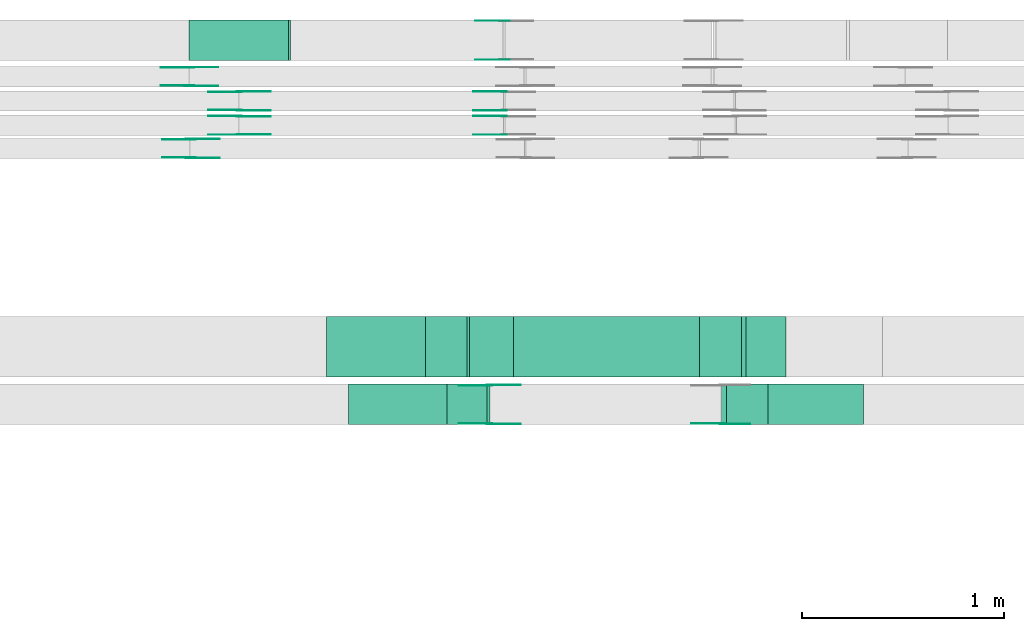
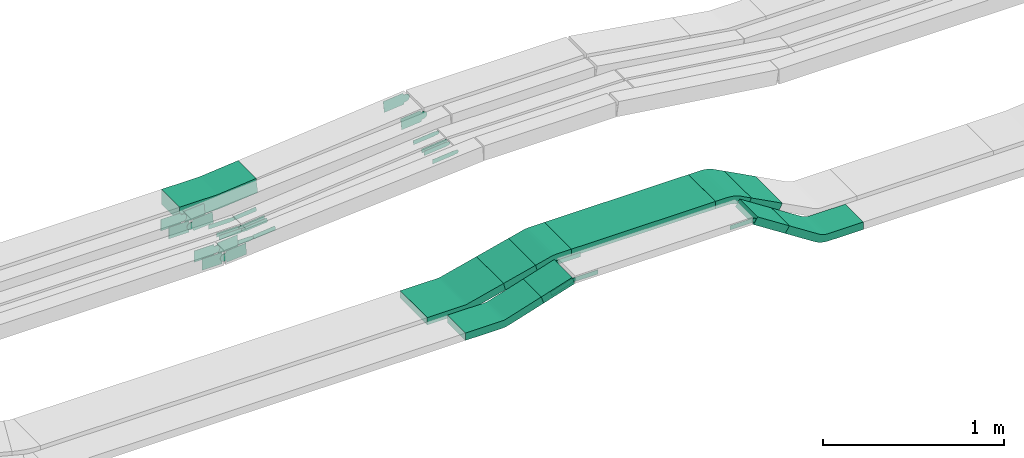
# One storey, part 17 of 28: 34 flow fittings, 5 flow segments.
"""IFC2X3 building model written with IfcOpenShell, lengths in millimetres."""

from ifc_helpers import new_model, entity, si_unit, converted_unit, derived_unit, direction, frame, frame_2d, origin, origin_2d_with_axis, place, context, subcontext, project, spatial, polyline, circle_curve, parameter, trimmed, segment, composite_curve, rectangle, outline, extrude, source, transform, mapped, material, type_object, type_shapes, element, save


model = new_model("IFC2X3")

# Units and contexts
model_context = context("Model", 3, precision=0.01, world=origin(), true_north=direction((6.12303176911189e-17, 1.0)))
body_context = subcontext(model_context, "Body", "Model", "MODEL_VIEW")
ifc_project = project(units=[si_unit("LENGTHUNIT", "METRE", prefix="MILLI"), si_unit("AREAUNIT", "SQUARE_METRE"), si_unit("VOLUMEUNIT", "CUBIC_METRE"), converted_unit("PLANEANGLEUNIT", "DEGREE", entity("IfcRatioMeasure", 0.0174532925199433), si_unit("PLANEANGLEUNIT", "RADIAN"), dimensions=[0, 0, 0, 0, 0, 0, 0]), si_unit("MASSUNIT", "GRAM", prefix="KILO"), derived_unit("MASSDENSITYUNIT", [(si_unit("MASSUNIT", "GRAM", prefix="KILO"), 1), (si_unit("LENGTHUNIT", "METRE"), -3)]), derived_unit("MOMENTOFINERTIAUNIT", [(si_unit("LENGTHUNIT", "METRE"), 4)]), si_unit("TIMEUNIT", "SECOND"), si_unit("FREQUENCYUNIT", "HERTZ"), si_unit("THERMODYNAMICTEMPERATUREUNIT", "DEGREE_CELSIUS"), derived_unit("THERMALTRANSMITTANCEUNIT", [(si_unit("MASSUNIT", "GRAM", prefix="KILO"), 1), (si_unit("THERMODYNAMICTEMPERATUREUNIT", "KELVIN"), -1), (si_unit("TIMEUNIT", "SECOND"), -3)]), derived_unit("VOLUMETRICFLOWRATEUNIT", [(si_unit("LENGTHUNIT", "METRE"), 3), (si_unit("TIMEUNIT", "SECOND"), -1)]), derived_unit("MASSFLOWRATEUNIT", [(si_unit("MASSUNIT", "GRAM", prefix="KILO"), 1), (si_unit("TIMEUNIT", "SECOND"), -1)]), derived_unit("ROTATIONALFREQUENCYUNIT", [(si_unit("TIMEUNIT", "SECOND"), -1)]), si_unit("ELECTRICCURRENTUNIT", "AMPERE"), si_unit("ELECTRICVOLTAGEUNIT", "VOLT"), si_unit("POWERUNIT", "WATT"), si_unit("FORCEUNIT", "NEWTON", prefix="KILO"), si_unit("ILLUMINANCEUNIT", "LUX"), si_unit("LUMINOUSFLUXUNIT", "LUMEN"), si_unit("LUMINOUSINTENSITYUNIT", "CANDELA"), derived_unit("USERDEFINED", [(si_unit("MASSUNIT", "GRAM", prefix="KILO"), -1), (si_unit("LENGTHUNIT", "METRE"), -2), (si_unit("TIMEUNIT", "SECOND"), 3), (si_unit("LUMINOUSFLUXUNIT", "LUMEN"), 1)]), derived_unit("LINEARVELOCITYUNIT", [(si_unit("LENGTHUNIT", "METRE"), 1), (si_unit("TIMEUNIT", "SECOND"), -1)]), si_unit("PRESSUREUNIT", "PASCAL"), derived_unit("USERDEFINED", [(si_unit("LENGTHUNIT", "METRE"), -2), (si_unit("MASSUNIT", "GRAM", prefix="KILO"), 1), (si_unit("TIMEUNIT", "SECOND"), -2)]), derived_unit("LINEARFORCEUNIT", [(si_unit("MASSUNIT", "GRAM", prefix="KILO"), 1), (si_unit("LENGTHUNIT", "METRE"), 1), (si_unit("TIMEUNIT", "SECOND"), -2), (si_unit("LENGTHUNIT", "METRE"), -1)]), derived_unit("PLANARFORCEUNIT", [(si_unit("MASSUNIT", "GRAM", prefix="KILO"), 1), (si_unit("LENGTHUNIT", "METRE"), 1), (si_unit("TIMEUNIT", "SECOND"), -2), (si_unit("LENGTHUNIT", "METRE"), -2)])], contexts=[model_context])

# Site, building, storey
site_placement = place(None, origin())
site = spatial("IfcSite", under=ifc_project, at=site_placement, CompositionType="ELEMENT")
building_placement = place(site_placement, origin())
building = spatial("IfcBuilding", under=site, at=building_placement, CompositionType="ELEMENT")
storey_placement = place(building_placement, frame((0.0, 0.0, 15900.0)))
storey = spatial("IfcBuildingStorey", under=building, at=storey_placement, CompositionType="ELEMENT", Elevation=15900.0)

# Flow segments
cable_carrier_segment_type = type_object("IfcCableCarrierSegmentType", PredefinedType="CABLETRAYSEGMENT")
flow_segment_1_placement = place(storey_placement, frame((50303.75, 14200.03, 2726.99)))
element("IfcFlowSegment", 1, at=flow_segment_1_placement, inside=storey, type_object=cable_carrier_segment_type, context=body_context, shape_type="SweptSolid", body=[
    extrude(rectangle(XDim=49.9999999999974, YDim=199.999999999998, at=origin_2d_with_axis()), frame((7.52, 100.0, 23.84), z_axis=(0.953675501505744, 0.0, 0.300837228128048), x_axis=(-0.300837228128048, 0.0, 0.953675501505744)), (0.0, 0.0, 1.0), 207.824130212316),
])
flow_segment_2_placement = place(storey_placement, frame((50198.04, 14435.03, 2711.72)))
element("IfcFlowSegment", 2, at=flow_segment_2_placement, inside=storey, type_object=cable_carrier_segment_type, context=body_context, shape_type="SweptSolid", body=[
    extrude(rectangle(XDim=49.9999999999986, YDim=211.330947385812, at=frame_2d((0.0, 0.0), x_axis=(0.0, 1.0))), frame((108.57, 0.0, 49.94), z_axis=(0.0, 1.0, 0.0), x_axis=(-0.969982804276857, 0.0, -0.243173517076191)), (0.0, 0.0, 1.0), 300.000000000003),
])
flow_segment_3_placement = place(storey_placement, frame((50633.03, 14435.03, 2790.0)))
element("IfcFlowSegment", 3, at=flow_segment_3_placement, inside=storey, type_object=cable_carrier_segment_type, context=body_context, shape_type="SweptSolid", body=[
    extrude(rectangle(XDim=920.040761116609, YDim=300.000000000001, at=origin_2d_with_axis()), frame((460.02, 150.0, 0.0), z_axis=(0.0, 0.0, 1.0), x_axis=(-1.0, 0.0, 0.0)), (0.0, 0.0, 1.0), 50.0000000000016),
])
flow_segment_4_placement = place(storey_placement, frame((51759.69, 14435.03, 2634.07)))
element("IfcFlowSegment", 4, at=flow_segment_4_placement, inside=storey, type_object=cable_carrier_segment_type, context=body_context, shape_type="SweptSolid", body=[
    extrude(rectangle(XDim=50.0000000000009, YDim=223.849365682387, at=frame_2d((0.0, 0.0), x_axis=(0.0, 1.0))), frame((110.63, 0.0, 74.43), z_axis=(0.0, 1.0, 0.0), x_axis=(0.883987864537297, 0.0, -0.467509845191296)), (0.0, 0.0, 1.0), 300.000000000001),
])
flow_segment_5_placement = place(storey_placement, frame((51660.11, 14200.03, 2657.66)))
element("IfcFlowSegment", 5, at=flow_segment_5_placement, inside=storey, type_object=cable_carrier_segment_type, context=body_context, shape_type="SweptSolid", body=[
    extrude(rectangle(XDim=49.9999999999933, YDim=200.000000000002, at=frame_2d((0.0, 0.0), x_axis=(0.0, 1.0))), frame((13.58, 100.0, 152.15), z_axis=(0.839568506992544, 0.0, -0.543253828395448), x_axis=(0.0, 1.0, 0.0)), (0.0, 0.0, 1.0), 241.428708971117),
])

# Flow fittings
ifc_material_1 = material(Name="G")
cable_carrier_fitting_type_1 = type_object("IfcCableCarrierFittingType", PredefinedType="NOTDEFINED", material=ifc_material_1)
shared_shape_1 = source(origin(), body_context, "Body", "SweptSolid", [
    extrude(outline(composite_curve([segment(trimmed(circle_curve(frame_2d((-44.59, 0.0), x_axis=(1.0, 0.0)), 12.5), [parameter(90.0000000000007)], [parameter(270.0)], True, "PARAMETER"), True, "CONTINUOUS"), segment(polyline([(-44.59, -12.5), (-33.09, -12.5)]), True, "CONTINUOUS"), segment(polyline([(-33.09, -12.5), (-31.23, -14.5)]), True, "CONTINUOUS"), segment(polyline([(-31.23, -14.5), (108.91, -14.5)]), True, "CONTINUOUS"), segment(polyline([(108.91, -14.5), (108.91, 14.5)]), True, "CONTINUOUS"), segment(polyline([(108.91, 14.5), (-31.23, 14.5)]), True, "CONTINUOUS"), segment(polyline([(-31.23, 14.5), (-33.09, 12.5)]), True, "CONTINUOUS"), segment(polyline([(-33.09, 12.5), (-44.59, 12.5)]), True, "CONTINUOUS")], self_intersect=False)), frame((44.59, 0.0, 0.0), z_axis=(0.0, 0.0, -1.0), x_axis=(1.0, 0.0, 0.0)), (0.0, 0.0, -1.0), 2.0),
])
type_shapes(cable_carrier_fitting_type_1, [shared_shape_1])
for number, where, z_axis, x_axis in (
    (6, (50588.36, 15634.0, 2787.2), (0.0, -1.0, 0.0), (-0.995479968225886, 0.0, -0.0949717476989256)),
    (7, (50588.36, 15754.0, 2787.2), (0.0, -1.0, 0.0), (-0.995479968225886, 0.0, -0.0949717476989256)),
    (8, (49278.6, 15754.0, 2662.24), (0.0, -1.0, 0.0), (0.995479968225886, 0.0, 0.0949717476989256)),
):
    element("IfcFlowFitting", number, at=place(storey_placement, frame(where, z_axis=z_axis, x_axis=x_axis)), inside=storey, type_object=cable_carrier_fitting_type_1, material=ifc_material_1, context=body_context, shape_type="MappedRepresentation", body=[
        mapped(shared_shape_1, transform((0.0, 0.0, 0.0), scale=1.0)),
    ])
cable_carrier_fitting_type_2 = type_object("IfcCableCarrierFittingType", PredefinedType="NOTDEFINED", material=ifc_material_1)
type_shapes(cable_carrier_fitting_type_2, [shared_shape_1])
flow_fitting_1_placement = place(storey_placement, frame((49278.6, 15842.92, 2662.24), z_axis=(0.0, 1.0, 0.0), x_axis=(-1.0, 0.0, 0.0)))
element("IfcFlowFitting", 9, at=flow_fitting_1_placement, inside=storey, type_object=cable_carrier_fitting_type_2, material=ifc_material_1, context=body_context, shape_type="MappedRepresentation", body=[
    mapped(shared_shape_1, transform((0.0, 0.0, 0.0), scale=1.0)),
])
flow_fitting_2_placement = place(storey_placement, frame((49278.6, 15724.92, 2662.24), z_axis=(0.0, 1.0, 0.0), x_axis=(-1.0, 0.0, 0.0)))
element("IfcFlowFitting", 10, at=flow_fitting_2_placement, inside=storey, type_object=cable_carrier_fitting_type_1, material=ifc_material_1, context=body_context, shape_type="MappedRepresentation", body=[
    mapped(shared_shape_1, transform((0.0, 0.0, 0.0), scale=1.0)),
])
flow_fitting_3_placement = place(storey_placement, frame((49278.6, 15636.0, 2662.24), z_axis=(0.0, -1.0, 0.0), x_axis=(0.995479968225887, 0.0, 0.0949717476989205)))
element("IfcFlowFitting", 11, at=flow_fitting_3_placement, inside=storey, type_object=cable_carrier_fitting_type_2, material=ifc_material_1, context=body_context, shape_type="MappedRepresentation", body=[
    mapped(shared_shape_1, transform((0.0, 0.0, 0.0), scale=1.0)),
])
flow_fitting_4_placement = place(storey_placement, frame((50514.68, 14395.49, 2815.0), z_axis=(0.0, 1.0, 0.0), x_axis=(1.0, 0.0, 0.0)))
element("IfcFlowFitting", 12, at=flow_fitting_4_placement, inside=storey, type_object=cable_carrier_fitting_type_1, material=ifc_material_1, context=body_context, shape_type="MappedRepresentation", body=[
    mapped(shared_shape_1, transform((0.0, 0.0, 0.0), scale=1.0)),
])
for number, where, z_axis, x_axis in (
    (13, (50514.68, 14206.57, 2815.0), (0.0, -1.0, 0.0), (-0.953675501505746, 0.0, -0.300837228128043)),
    (14, (51665.66, 14206.57, 2815.0), (0.0, -1.0, 0.0), (-1.0, 0.0, 0.0)),
):
    element("IfcFlowFitting", number, at=place(storey_placement, frame(where, z_axis=z_axis, x_axis=x_axis)), inside=storey, type_object=cable_carrier_fitting_type_2, material=ifc_material_1, context=body_context, shape_type="MappedRepresentation", body=[
        mapped(shared_shape_1, transform((0.0, 0.0, 0.0), scale=1.0)),
    ])
cable_carrier_fitting_type_3 = type_object("IfcCableCarrierFittingType", PredefinedType="NOTDEFINED", material=ifc_material_1)
shared_shape_2 = source(origin(), body_context, "Body", "SweptSolid", [
    extrude(outline(composite_curve([segment(trimmed(circle_curve(frame_2d((-44.59, 0.0), x_axis=(1.0, 0.0)), 12.5), [parameter(90.0000000000007)], [parameter(270.0)], True, "PARAMETER"), True, "CONTINUOUS"), segment(polyline([(-44.59, -12.5), (-33.09, -12.5)]), True, "CONTINUOUS"), segment(polyline([(-33.09, -12.5), (-31.23, -14.5)]), True, "CONTINUOUS"), segment(polyline([(-31.23, -14.5), (108.91, -14.5)]), True, "CONTINUOUS"), segment(polyline([(108.91, -14.5), (108.91, 14.5)]), True, "CONTINUOUS"), segment(polyline([(108.91, 14.5), (-31.23, 14.5)]), True, "CONTINUOUS"), segment(polyline([(-31.23, 14.5), (-33.09, 12.5)]), True, "CONTINUOUS"), segment(polyline([(-33.09, 12.5), (-44.59, 12.5)]), True, "CONTINUOUS")], self_intersect=False)), frame((44.59, 0.0, 0.0)), (0.0, 0.0, 1.0), 2.0),
])
type_shapes(cable_carrier_fitting_type_3, [shared_shape_2])
for number, where, z_axis, x_axis in (
    (15, (50588.36, 15724.92, 2787.2), (0.0, 1.0, 0.0), (-0.995479968225886, 0.0, -0.0949717476989256)),
    (16, (50588.36, 15844.92, 2787.2), (0.0, 1.0, 0.0), (-0.995479968225886, 0.0, -0.0949717476989256)),
    (17, (49278.6, 15844.92, 2662.24), (0.0, 1.0, 0.0), (0.995479968225886, 0.0, 0.0949717476989256)),
):
    element("IfcFlowFitting", number, at=place(storey_placement, frame(where, z_axis=z_axis, x_axis=x_axis)), inside=storey, type_object=cable_carrier_fitting_type_3, material=ifc_material_1, context=body_context, shape_type="MappedRepresentation", body=[
        mapped(shared_shape_2, transform((0.0, 0.0, 0.0), scale=1.0)),
    ])
cable_carrier_fitting_type_4 = type_object("IfcCableCarrierFittingType", PredefinedType="NOTDEFINED", material=ifc_material_1)
type_shapes(cable_carrier_fitting_type_4, [shared_shape_2])
flow_fitting_5_placement = place(storey_placement, frame((49278.6, 15756.0, 2662.24), z_axis=(0.0, -1.0, 0.0), x_axis=(-1.0, 0.0, 0.0)))
element("IfcFlowFitting", 18, at=flow_fitting_5_placement, inside=storey, type_object=cable_carrier_fitting_type_4, material=ifc_material_1, context=body_context, shape_type="MappedRepresentation", body=[
    mapped(shared_shape_2, transform((0.0, 0.0, 0.0), scale=1.0)),
])
flow_fitting_6_placement = place(storey_placement, frame((49278.6, 15634.0, 2662.24), z_axis=(0.0, -1.0, 0.0), x_axis=(-1.0, 0.0, 0.0)))
element("IfcFlowFitting", 19, at=flow_fitting_6_placement, inside=storey, type_object=cable_carrier_fitting_type_3, material=ifc_material_1, context=body_context, shape_type="MappedRepresentation", body=[
    mapped(shared_shape_2, transform((0.0, 0.0, 0.0), scale=1.0)),
])
flow_fitting_7_placement = place(storey_placement, frame((49278.6, 15722.92, 2662.24), z_axis=(0.0, 1.0, 0.0), x_axis=(0.995479968225887, 0.0, 0.0949717476989205)))
element("IfcFlowFitting", 20, at=flow_fitting_7_placement, inside=storey, type_object=cable_carrier_fitting_type_4, material=ifc_material_1, context=body_context, shape_type="MappedRepresentation", body=[
    mapped(shared_shape_2, transform((0.0, 0.0, 0.0), scale=1.0)),
])
flow_fitting_8_placement = place(storey_placement, frame((50514.68, 14204.57, 2815.0), z_axis=(0.0, -1.0, 0.0), x_axis=(1.0, 0.0, 0.0)))
element("IfcFlowFitting", 21, at=flow_fitting_8_placement, inside=storey, type_object=cable_carrier_fitting_type_3, material=ifc_material_1, context=body_context, shape_type="MappedRepresentation", body=[
    mapped(shared_shape_2, transform((0.0, 0.0, 0.0), scale=1.0)),
])
flow_fitting_9_placement = place(storey_placement, frame((50514.68, 14393.49, 2815.0), z_axis=(0.0, 1.0, 0.0), x_axis=(-0.953675501505746, 0.0, -0.300837228128043)))
element("IfcFlowFitting", 22, at=flow_fitting_9_placement, inside=storey, type_object=cable_carrier_fitting_type_4, material=ifc_material_1, context=body_context, shape_type="MappedRepresentation", body=[
    mapped(shared_shape_2, transform((0.0, 0.0, 0.0), scale=1.0)),
])
flow_fitting_10_placement = place(storey_placement, frame((51665.66, 14204.57, 2815.0), z_axis=(0.0, -1.0, 0.0), x_axis=(0.839568506992486, 0.0, -0.543253828395537)))
element("IfcFlowFitting", 23, at=flow_fitting_10_placement, inside=storey, type_object=cable_carrier_fitting_type_3, material=ifc_material_1, context=body_context, shape_type="MappedRepresentation", body=[
    mapped(shared_shape_2, transform((0.0, 0.0, 0.0), scale=1.0)),
])
cable_carrier_fitting_type_5 = type_object("IfcCableCarrierFittingType", PredefinedType="NOTDEFINED", material=ifc_material_1)
shared_shape_3 = source(origin(), body_context, "Body", "SweptSolid", [
    extrude(outline(composite_curve([segment(trimmed(circle_curve(frame_2d((-41.47, 0.0), x_axis=(1.0, 0.0)), 25.0), [parameter(90.0000000000007)], [parameter(270.0)], True, "PARAMETER"), True, "CONTINUOUS"), segment(polyline([(-41.47, -25.0), (-29.97, -25.0)]), True, "CONTINUOUS"), segment(polyline([(-29.97, -25.0), (-28.1, -38.5)]), True, "CONTINUOUS"), segment(polyline([(-28.1, -38.5), (99.53, -38.5)]), True, "CONTINUOUS"), segment(polyline([(99.53, -38.5), (99.53, 38.5)]), True, "CONTINUOUS"), segment(polyline([(99.53, 38.5), (-28.1, 38.5)]), True, "CONTINUOUS"), segment(polyline([(-28.1, 38.5), (-29.97, 25.0)]), True, "CONTINUOUS"), segment(polyline([(-29.97, 25.0), (-41.47, 25.0)]), True, "CONTINUOUS")], self_intersect=False)), frame((41.47, 0.0, 0.0), z_axis=(0.0, 0.0, -1.0), x_axis=(1.0, 0.0, 0.0)), (0.0, 0.0, -1.0), 2.0),
])
type_shapes(cable_carrier_fitting_type_5, [shared_shape_3])
flow_fitting_11_placement = place(storey_placement, frame((49030.04, 15874.53, 2685.0), z_axis=(0.0, -1.0, 0.0), x_axis=(0.997185843977155, 0.0, 0.0749692775179912)))
element("IfcFlowFitting", 24, at=flow_fitting_11_placement, inside=storey, type_object=cable_carrier_fitting_type_5, material=ifc_material_1, context=body_context, shape_type="MappedRepresentation", body=[
    mapped(shared_shape_3, transform((0.0, 0.0, 0.0), scale=1.0)),
])
cable_carrier_fitting_type_6 = type_object("IfcCableCarrierFittingType", PredefinedType="NOTDEFINED", material=ifc_material_1)
type_shapes(cable_carrier_fitting_type_6, [shared_shape_3])
flow_fitting_12_placement = place(storey_placement, frame((49030.04, 15963.45, 2685.0), z_axis=(0.0, 1.0, 0.0), x_axis=(-1.0, 0.0, 0.0)))
element("IfcFlowFitting", 25, at=flow_fitting_12_placement, inside=storey, type_object=cable_carrier_fitting_type_6, material=ifc_material_1, context=body_context, shape_type="MappedRepresentation", body=[
    mapped(shared_shape_3, transform((0.0, 0.0, 0.0), scale=1.0)),
])
flow_fitting_13_placement = place(storey_placement, frame((49037.41, 15519.53, 2684.95), z_axis=(0.0, -1.0, 0.0), x_axis=(0.997183128198858, 0.0, 0.0750053920431093)))
element("IfcFlowFitting", 26, at=flow_fitting_13_placement, inside=storey, type_object=cable_carrier_fitting_type_5, material=ifc_material_1, context=body_context, shape_type="MappedRepresentation", body=[
    mapped(shared_shape_3, transform((0.0, 0.0, 0.0), scale=1.0)),
])
flow_fitting_14_placement = place(storey_placement, frame((49037.41, 15608.45, 2684.95), z_axis=(0.0, 1.0, 0.0), x_axis=(-1.0, 0.0, 0.0)))
element("IfcFlowFitting", 27, at=flow_fitting_14_placement, inside=storey, type_object=cable_carrier_fitting_type_6, material=ifc_material_1, context=body_context, shape_type="MappedRepresentation", body=[
    mapped(shared_shape_3, transform((0.0, 0.0, 0.0), scale=1.0)),
])
flow_fitting_15_placement = place(storey_placement, frame((50588.72, 16004.53, 2810.0), z_axis=(0.0, -1.0, 0.0), x_axis=(-0.995479968225886, 0.0, -0.0949717476989308)))
element("IfcFlowFitting", 28, at=flow_fitting_15_placement, inside=storey, type_object=cable_carrier_fitting_type_5, material=ifc_material_1, context=body_context, shape_type="MappedRepresentation", body=[
    mapped(shared_shape_3, transform((0.0, 0.0, 0.0), scale=1.0)),
])
cable_carrier_fitting_type_7 = type_object("IfcCableCarrierFittingType", PredefinedType="NOTDEFINED", material=ifc_material_1)
shared_shape_4 = source(origin(), body_context, "Body", "SweptSolid", [
    extrude(outline(composite_curve([segment(trimmed(circle_curve(frame_2d((-41.47, 0.0), x_axis=(1.0, 0.0)), 25.0), [parameter(90.0000000000007)], [parameter(270.0)], True, "PARAMETER"), True, "CONTINUOUS"), segment(polyline([(-41.47, -25.0), (-29.97, -25.0)]), True, "CONTINUOUS"), segment(polyline([(-29.97, -25.0), (-28.1, -38.5)]), True, "CONTINUOUS"), segment(polyline([(-28.1, -38.5), (99.53, -38.5)]), True, "CONTINUOUS"), segment(polyline([(99.53, -38.5), (99.53, 38.5)]), True, "CONTINUOUS"), segment(polyline([(99.53, 38.5), (-28.1, 38.5)]), True, "CONTINUOUS"), segment(polyline([(-28.1, 38.5), (-29.97, 25.0)]), True, "CONTINUOUS"), segment(polyline([(-29.97, 25.0), (-41.47, 25.0)]), True, "CONTINUOUS")], self_intersect=False)), frame((41.47, 0.0, 0.0)), (0.0, 0.0, 1.0), 2.0),
])
type_shapes(cable_carrier_fitting_type_7, [shared_shape_4])
flow_fitting_16_placement = place(storey_placement, frame((49030.04, 15965.45, 2685.0), z_axis=(0.0, 1.0, 0.0), x_axis=(0.997185843977155, 0.0, 0.0749692775179912)))
element("IfcFlowFitting", 29, at=flow_fitting_16_placement, inside=storey, type_object=cable_carrier_fitting_type_7, material=ifc_material_1, context=body_context, shape_type="MappedRepresentation", body=[
    mapped(shared_shape_4, transform((0.0, 0.0, 0.0), scale=1.0)),
])
cable_carrier_fitting_type_8 = type_object("IfcCableCarrierFittingType", PredefinedType="NOTDEFINED", material=ifc_material_1)
type_shapes(cable_carrier_fitting_type_8, [shared_shape_4])
flow_fitting_17_placement = place(storey_placement, frame((49030.04, 15876.53, 2685.0), z_axis=(0.0, -1.0, 0.0), x_axis=(-1.0, 0.0, 0.0)))
element("IfcFlowFitting", 30, at=flow_fitting_17_placement, inside=storey, type_object=cable_carrier_fitting_type_8, material=ifc_material_1, context=body_context, shape_type="MappedRepresentation", body=[
    mapped(shared_shape_4, transform((0.0, 0.0, 0.0), scale=1.0)),
])
flow_fitting_18_placement = place(storey_placement, frame((49037.41, 15610.45, 2684.95), z_axis=(0.0, 1.0, 0.0), x_axis=(0.997183128198858, 0.0, 0.0750053920431093)))
element("IfcFlowFitting", 31, at=flow_fitting_18_placement, inside=storey, type_object=cable_carrier_fitting_type_7, material=ifc_material_1, context=body_context, shape_type="MappedRepresentation", body=[
    mapped(shared_shape_4, transform((0.0, 0.0, 0.0), scale=1.0)),
])
flow_fitting_19_placement = place(storey_placement, frame((49037.41, 15521.53, 2684.95), z_axis=(0.0, -1.0, 0.0), x_axis=(-1.0, 0.0, 0.0)))
element("IfcFlowFitting", 32, at=flow_fitting_19_placement, inside=storey, type_object=cable_carrier_fitting_type_8, material=ifc_material_1, context=body_context, shape_type="MappedRepresentation", body=[
    mapped(shared_shape_4, transform((0.0, 0.0, 0.0), scale=1.0)),
])
flow_fitting_20_placement = place(storey_placement, frame((50588.72, 16195.45, 2810.0), z_axis=(0.0, 1.0, 0.0), x_axis=(-0.995479968225886, 0.0, -0.0949717476989308)))
element("IfcFlowFitting", 33, at=flow_fitting_20_placement, inside=storey, type_object=cable_carrier_fitting_type_7, material=ifc_material_1, context=body_context, shape_type="MappedRepresentation", body=[
    mapped(shared_shape_4, transform((0.0, 0.0, 0.0), scale=1.0)),
])
ifc_material_2 = material()
cable_carrier_fitting_type_9 = type_object("IfcCableCarrierFittingType", Name="470_DKC_S5_CS 90 internal vertical angle:-", PredefinedType="NOTDEFINED", material=ifc_material_2)
shared_shape_5 = source(origin(), body_context, "Body", "SweptSolid", [
    extrude(outline(composite_curve([segment(polyline([(-247.9, -56.08), (-7.56, -56.08)]), True, "CONTINUOUS"), segment(trimmed(circle_curve(frame_2d((-7.56, 158.92), x_axis=(0.0, -1.0)), 214.999999999999), [parameter(0.0)], [parameter(5.4496937226348)], True, "PARAMETER"), True, "CONTINUOUS"), segment(polyline([(12.86, -55.11), (252.1, -32.28)]), True, "CONTINUOUS"), segment(polyline([(252.1, -32.28), (242.61, 67.27)]), True, "CONTINUOUS"), segment(polyline([(242.61, 67.27), (3.36, 44.44)]), True, "CONTINUOUS"), segment(trimmed(circle_curve(frame_2d((-7.56, 158.92), x_axis=(0.0, -1.0)), 114.999999999999), [parameter(0.0)], [parameter(5.4496937226348)], True, "PARAMETER"), False, "CONTINUOUS"), segment(polyline([(-7.56, 43.92), (-247.9, 43.92)]), True, "CONTINUOUS"), segment(polyline([(-247.9, 43.92), (-247.9, -56.08)]), True, "CONTINUOUS")], self_intersect=False)), frame((-0.29, 6.08, -100.0)), (0.0, 0.0, 1.0), 200.0),
])
type_shapes(cable_carrier_fitting_type_9, [shared_shape_5])
flow_fitting_21_placement = place(storey_placement, frame((49278.49, 16099.99, 2685.0), z_axis=(0.0, -1.0, 0.0), x_axis=(1.0, 0.0, 0.0)))
element("IfcFlowFitting", 34, at=flow_fitting_21_placement, inside=storey, type_object=cable_carrier_fitting_type_9, material=ifc_material_2, Name="470_DKC_S5_CS 90 internal vertical angle:-", ObjectType="470_DKC_S5_CS 90 internal vertical angle:-", context=body_context, shape_type="MappedRepresentation", body=[
    mapped(shared_shape_5, transform((0.0, 0.0, 0.0), scale=1.0)),
])
cable_carrier_fitting_type_10 = type_object("IfcCableCarrierFittingType", Name="470_DKC_S5_CS 90 internal vertical angle:-", PredefinedType="NOTDEFINED", material=ifc_material_2)
shared_shape_6 = source(origin(), body_context, "Body", "SweptSolid", [
    extrude(outline(composite_curve([segment(polyline([(-248.91, -45.58), (-18.39, -45.58)]), True, "CONTINUOUS"), segment(trimmed(circle_curve(frame_2d((-18.39, 119.42), x_axis=(0.0, -1.0)), 164.999999999999), [parameter(0.0)], [parameter(17.5078959161392)], True, "PARAMETER"), True, "CONTINUOUS"), segment(polyline([(31.25, -37.94), (251.09, 31.41)]), True, "CONTINUOUS"), segment(polyline([(251.09, 31.41), (236.05, 79.1)]), True, "CONTINUOUS"), segment(polyline([(236.05, 79.1), (16.21, 9.75)]), True, "CONTINUOUS"), segment(trimmed(circle_curve(frame_2d((-18.39, 119.42), x_axis=(0.0, -1.0)), 114.999999999999), [parameter(0.0)], [parameter(17.5078959161392)], True, "PARAMETER"), False, "CONTINUOUS"), segment(polyline([(-18.39, 4.42), (-248.91, 4.42)]), True, "CONTINUOUS"), segment(polyline([(-248.91, 4.42), (-248.91, -45.58)]), True, "CONTINUOUS")], self_intersect=False)), frame((-3.17, 20.58, -100.0)), (0.0, 0.0, 1.0), 200.0),
])
type_shapes(cable_carrier_fitting_type_10, [shared_shape_6])
flow_fitting_22_placement = place(storey_placement, frame((50070.87, 14300.03, 2675.0), z_axis=(0.0, -1.0, 0.0), x_axis=(1.0, 0.0, 0.0)))
element("IfcFlowFitting", 35, at=flow_fitting_22_placement, inside=storey, type_object=cable_carrier_fitting_type_10, material=ifc_material_2, Name="470_DKC_S5_CS 90 internal vertical angle:-", ObjectType="470_DKC_S5_CS 90 internal vertical angle:-", context=body_context, shape_type="MappedRepresentation", body=[
    mapped(shared_shape_6, transform((0.0, 0.0, 0.0), scale=1.0)),
])
cable_carrier_fitting_type_11 = type_object("IfcCableCarrierFittingType", Name="470_DKC_S5_CS 90 internal vertical angle:-", PredefinedType="NOTDEFINED", material=ifc_material_2)
shared_shape_7 = source(origin(), body_context, "Body", "SweptSolid", [
    extrude(outline(composite_curve([segment(polyline([(-248.71, -41.29), (-15.27, -41.29)]), True, "CONTINUOUS"), segment(trimmed(circle_curve(frame_2d((-15.27, 123.71), x_axis=(0.0, -1.0)), 164.999999999999), [parameter(0.0)], [parameter(14.0739199213607)], True, "PARAMETER"), True, "CONTINUOUS"), segment(polyline([(24.85, -36.34), (251.29, 20.43)]), True, "CONTINUOUS"), segment(polyline([(251.29, 20.43), (239.13, 68.93)]), True, "CONTINUOUS"), segment(polyline([(239.13, 68.93), (12.69, 12.16)]), True, "CONTINUOUS"), segment(trimmed(circle_curve(frame_2d((-15.27, 123.71), x_axis=(0.0, -1.0)), 114.999999999999), [parameter(0.0)], [parameter(14.0739199213607)], True, "PARAMETER"), False, "CONTINUOUS"), segment(polyline([(-15.27, 8.71), (-248.71, 8.71)]), True, "CONTINUOUS"), segment(polyline([(-248.71, 8.71), (-248.71, -41.29)]), True, "CONTINUOUS")], self_intersect=False)), frame((-2.01, 16.29, -150.0)), (0.0, 0.0, 1.0), 300.0),
])
type_shapes(cable_carrier_fitting_type_11, [shared_shape_7])
flow_fitting_23_placement = place(storey_placement, frame((49960.92, 14585.03, 2675.0), z_axis=(0.0, -1.0, 0.0), x_axis=(1.0, 0.0, 0.0)))
element("IfcFlowFitting", 36, at=flow_fitting_23_placement, inside=storey, type_object=cable_carrier_fitting_type_11, material=ifc_material_2, Name="470_DKC_S5_CS 90 internal vertical angle:-", ObjectType="470_DKC_S5_CS 90 internal vertical angle:-", context=body_context, shape_type="MappedRepresentation", body=[
    mapped(shared_shape_7, transform((0.0, 0.0, 0.0), scale=1.0)),
])
cable_carrier_fitting_type_12 = type_object("IfcCableCarrierFittingType", Name="470_DKC_S5_CD 90 external vertical angle:-", PredefinedType="NOTDEFINED", material=ifc_material_2)
shared_shape_8 = source(origin(), body_context, "Body", "SweptSolid", [
    extrude(outline(composite_curve([segment(polyline([(-112.66, -33.15), (-19.36, -33.15)]), True, "CONTINUOUS"), segment(trimmed(circle_curve(frame_2d((-19.36, 156.85), x_axis=(0.0, -1.0)), 189.999999999999), [parameter(0.0)], [parameter(14.0739199213607)], True, "PARAMETER"), True, "CONTINUOUS"), segment(polyline([(26.84, -27.45), (117.34, -4.76)]), True, "CONTINUOUS"), segment(polyline([(117.34, -4.76), (105.18, 43.74)]), True, "CONTINUOUS"), segment(polyline([(105.18, 43.74), (14.68, 21.05)]), True, "CONTINUOUS"), segment(trimmed(circle_curve(frame_2d((-19.36, 156.85), x_axis=(0.0, -1.0)), 139.999999999999), [parameter(0.0)], [parameter(14.0739199213607)], True, "PARAMETER"), False, "CONTINUOUS"), segment(polyline([(-19.36, 16.85), (-112.66, 16.85)]), True, "CONTINUOUS"), segment(polyline([(-112.66, 16.85), (-112.66, -33.15)]), True, "CONTINUOUS")], self_intersect=False)), frame((-1.01, 8.15, -150.0)), (0.0, 0.0, 1.0), 300.0),
])
type_shapes(cable_carrier_fitting_type_12, [shared_shape_8])
flow_fitting_24_placement = place(storey_placement, frame((50519.36, 14585.03, 2815.0), z_axis=(0.0, 1.0, 0.0), x_axis=(0.969982804276865, 0.0, 0.243173517076161)))
element("IfcFlowFitting", 37, at=flow_fitting_24_placement, inside=storey, type_object=cable_carrier_fitting_type_12, material=ifc_material_2, Name="470_DKC_S5_CD 90 external vertical angle:-", ObjectType="470_DKC_S5_CD 90 external vertical angle:-", context=body_context, shape_type="MappedRepresentation", body=[
    mapped(shared_shape_8, transform((0.0, 0.0, 0.0), scale=1.0)),
])
cable_carrier_fitting_type_13 = type_object("IfcCableCarrierFittingType", Name="470_DKC_S5_CD 90 external vertical angle:-", PredefinedType="NOTDEFINED", material=ifc_material_2)
shared_shape_9 = source(origin(), body_context, "Body", "SweptSolid", [
    extrude(outline(composite_curve([segment(polyline([(-111.33, -43.33), (-36.4, -43.33)]), True, "CONTINUOUS"), segment(trimmed(circle_curve(frame_2d((-36.4, 146.67), x_axis=(0.0, -1.0)), 189.999999999999), [parameter(0.0)], [parameter(27.8727762328618)], True, "PARAMETER"), True, "CONTINUOUS"), segment(polyline([(52.43, -21.29), (118.67, 13.75)]), True, "CONTINUOUS"), segment(polyline([(118.67, 13.75), (95.3, 57.94)]), True, "CONTINUOUS"), segment(polyline([(95.3, 57.94), (29.06, 22.91)]), True, "CONTINUOUS"), segment(trimmed(circle_curve(frame_2d((-36.4, 146.67), x_axis=(0.0, -1.0)), 139.999999999999), [parameter(0.0)], [parameter(27.8727762328618)], True, "PARAMETER"), False, "CONTINUOUS"), segment(polyline([(-36.4, 6.67), (-111.33, 6.67)]), True, "CONTINUOUS"), segment(polyline([(-111.33, 6.67), (-111.33, -43.33)]), True, "CONTINUOUS")], self_intersect=False)), frame((-4.55, 18.33, -150.0)), (0.0, 0.0, 1.0), 300.0),
])
type_shapes(cable_carrier_fitting_type_13, [shared_shape_9])
flow_fitting_25_placement = place(storey_placement, frame((51668.95, 14585.03, 2815.0), z_axis=(0.0, 1.0, 0.0), x_axis=(1.0, 0.0, 0.0)))
element("IfcFlowFitting", 38, at=flow_fitting_25_placement, inside=storey, type_object=cable_carrier_fitting_type_13, material=ifc_material_2, Name="470_DKC_S5_CD 90 external vertical angle:-", ObjectType="470_DKC_S5_CD 90 external vertical angle:-", context=body_context, shape_type="MappedRepresentation", body=[
    mapped(shared_shape_9, transform((0.0, 0.0, 0.0), scale=1.0)),
])
cable_carrier_fitting_type_14 = type_object("IfcCableCarrierFittingType", Name="470_DKC_S5_CS 90 internal vertical angle:-", PredefinedType="NOTDEFINED", material=ifc_material_2)
shared_shape_10 = source(origin(), body_context, "Body", "SweptSolid", [
    extrude(outline(composite_curve([segment(polyline([(-252.16, -66.53), (-29.08, -66.53)]), True, "CONTINUOUS"), segment(trimmed(circle_curve(frame_2d((-29.08, 98.47), x_axis=(0.0, -1.0)), 164.999999999999), [parameter(0.0)], [parameter(32.9054169620784)], True, "PARAMETER"), True, "CONTINUOUS"), segment(polyline([(60.56, -40.06), (247.84, 81.13)]), True, "CONTINUOUS"), segment(polyline([(247.84, 81.13), (220.68, 123.11)]), True, "CONTINUOUS"), segment(polyline([(220.68, 123.11), (33.39, 1.92)]), True, "CONTINUOUS"), segment(trimmed(circle_curve(frame_2d((-29.08, 98.47), x_axis=(0.0, -1.0)), 114.999999999999), [parameter(0.0)], [parameter(32.9054169620784)], True, "PARAMETER"), False, "CONTINUOUS"), segment(polyline([(-29.08, -16.53), (-252.16, -16.53)]), True, "CONTINUOUS"), segment(polyline([(-252.16, -16.53), (-252.16, -66.53)]), True, "CONTINUOUS")], self_intersect=False)), frame((-12.26, 41.53, -100.0)), (0.0, 0.0, 1.0), 200.0),
])
type_shapes(cable_carrier_fitting_type_14, [shared_shape_10])
flow_fitting_26_placement = place(storey_placement, frame((52098.38, 14300.03, 2535.0), z_axis=(0.0, -1.0, 0.0), x_axis=(0.839568506992486, 0.0, -0.543253828395537)))
element("IfcFlowFitting", 39, at=flow_fitting_26_placement, inside=storey, type_object=cable_carrier_fitting_type_14, material=ifc_material_2, Name="470_DKC_S5_CS 90 internal vertical angle:-", ObjectType="470_DKC_S5_CS 90 internal vertical angle:-", context=body_context, shape_type="MappedRepresentation", body=[
    mapped(shared_shape_10, transform((0.0, 0.0, 0.0), scale=1.0)),
])

save(model, "model.ifc")
